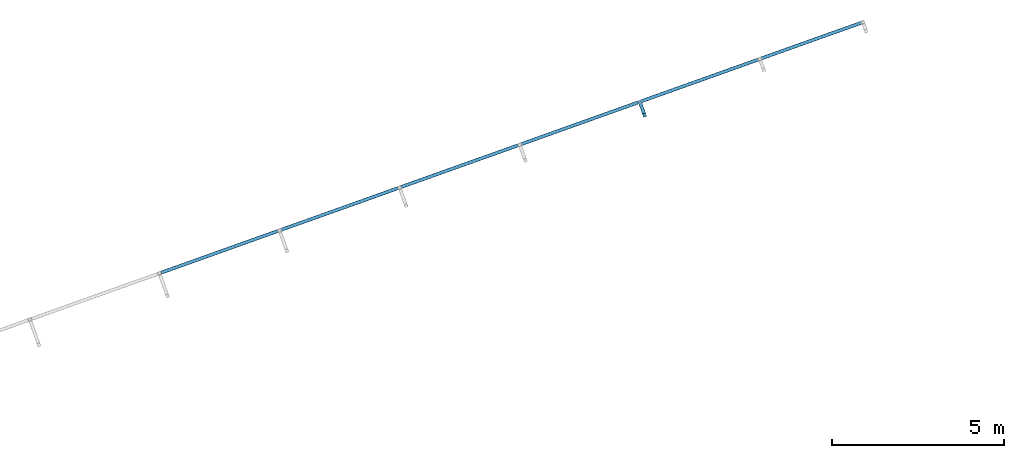
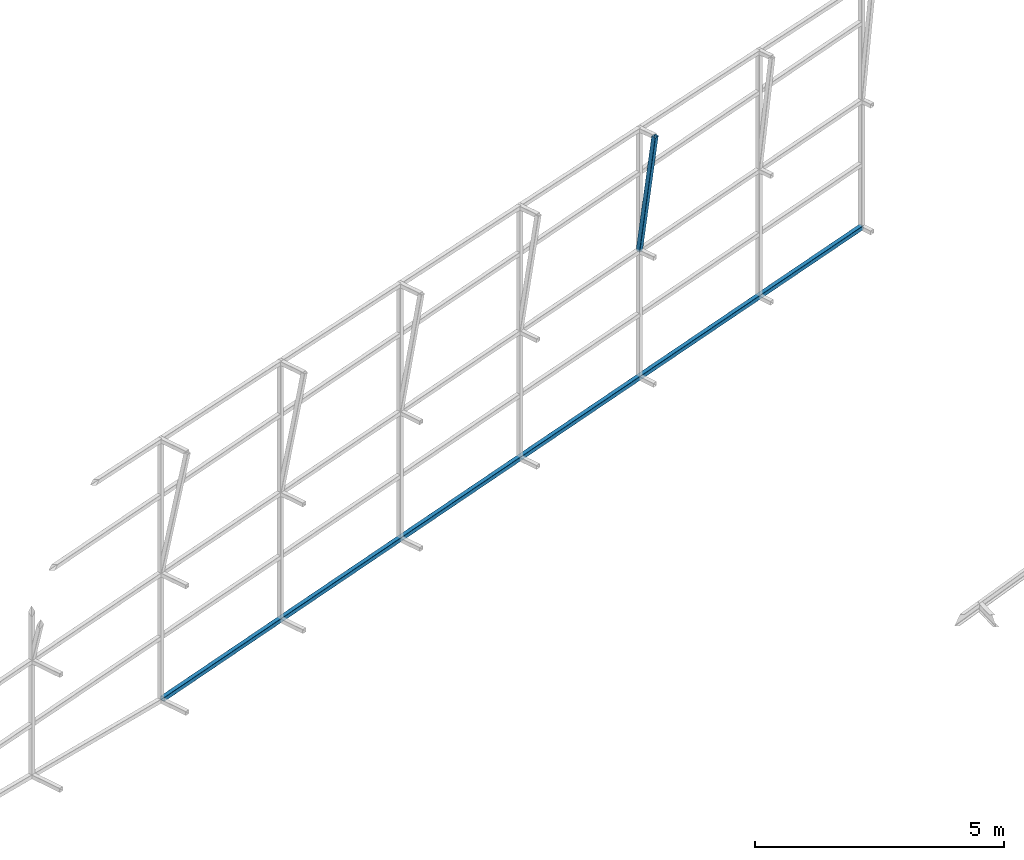
# One storey, part 138 of 215: 1 beam, 1 member, 2 elements without a shape of their own.
"""IFC2X3 building model written with IfcOpenShell, lengths in millimetres."""

from ifc_helpers import new_model, si_unit, frame, origin_with_axes, origin_2d_with_axis, place, context, subcontext, project, spatial, hollow_rectangle, extrude, material, type_object, element, aggregate, save


model = new_model("IFC2X3")

# Units and contexts
model_context = context("Model", 3, precision=1e-05, world=origin_with_axes())
body_context = subcontext(model_context, "Body", "Model", "MODEL_VIEW")
ifc_project = project(units=[si_unit("LENGTHUNIT", "METRE", prefix="MILLI"), si_unit("AREAUNIT", "SQUARE_METRE"), si_unit("VOLUMEUNIT", "CUBIC_METRE"), si_unit("MASSUNIT", "GRAM", prefix="KILO"), si_unit("TIMEUNIT", "SECOND"), si_unit("PLANEANGLEUNIT", "RADIAN"), si_unit("SOLIDANGLEUNIT", "STERADIAN"), si_unit("THERMODYNAMICTEMPERATUREUNIT", "DEGREE_CELSIUS"), si_unit("LUMINOUSINTENSITYUNIT", "LUMEN")], contexts=[model_context])

# Site, building, storey
site_placement = place(None, origin_with_axes())
site = spatial("IfcSite", under=ifc_project, at=site_placement, CompositionType="ELEMENT")
building_placement = place(site_placement, origin_with_axes())
building = spatial("IfcBuilding", under=site, at=building_placement, Name="Undefined", CompositionType="ELEMENT")
storey_placement = place(building_placement, origin_with_axes())
storey = spatial("IfcBuildingStorey", under=building, at=storey_placement, Name="Undefined", CompositionType="ELEMENT", Elevation=0.0)

# Assembly, beam
assembly_1_placement = place(storey_placement, origin_with_axes())
assembly_1 = element("IfcElementAssembly", 1, at=assembly_1_placement, inside=storey, Name="Steel Assembly", AssemblyPlace="NOTDEFINED", PredefinedType="RIGID_FRAME")
ifc_material = material(Name="STEEL/S275JR")
beam_type = type_object("IfcBeamType", PredefinedType="NOTDEFINED")
beam_placement = place(assembly_1_placement, frame((124257.142459985, 82932.5294511076, 150.001877230739), z_axis=(0.0, 0.0, -1.0), x_axis=(0.941802170974673, 0.33616762299096, 0.0)))
beam = element("IfcBeam", 2, at=beam_placement, type_object=beam_type, material=ifc_material, Name="LISSE", context=body_context, shape_type="SweptSolid", body=[
    extrude(hollow_rectangle(XDim=100.0, YDim=100.0, WallThickness=4.0, InnerFilletRadius=4.0, OuterFilletRadius=8.0, at=origin_2d_with_axis()), frame((21719.6101361096, 0.0, 0.0), z_axis=(-1.0, 0.0, 0.0), x_axis=(-6.93889390390723e-18, -1.0, -3.46944695195361e-18)), (0.0, 0.0, 1.0), 21719.6),
])
aggregate(assembly_1, [beam])

# Assembly, member
assembly_2_placement = place(storey_placement, origin_with_axes())
assembly_2 = element("IfcElementAssembly", 3, at=assembly_2_placement, inside=storey, Name="Steel Assembly", AssemblyPlace="NOTDEFINED", PredefinedType="RIGID_FRAME")
member_type = type_object("IfcMemberType", PredefinedType="NOTDEFINED")
member_placement = place(assembly_2_placement, frame((138350.096970345, 87521.9744258463, 6258.63580086908), z_axis=(0.941802170974673, 0.33616762299096, 0.0), x_axis=(-0.0461021260047772, 0.129161289013395, -0.990551339102743)))
member = element("IfcMember", 4, at=member_placement, type_object=member_type, material=ifc_material, Name="LISSE", context=body_context, shape_type="SweptSolid", body=[
    extrude(hollow_rectangle(XDim=100.0, YDim=100.0, WallThickness=4.0, InnerFilletRadius=4.0, OuterFilletRadius=8.0, at=origin_2d_with_axis()), frame((3027.24126719019, 0.0, -2.90819458804317e-11), z_axis=(-1.0, 0.0, 0.0), x_axis=(-6.93889390390723e-18, -1.0, -3.46944695195361e-18)), (0.0, 0.0, 1.0), 3027.2),
])
aggregate(assembly_2, [member])

save(model, "model.ifc")
